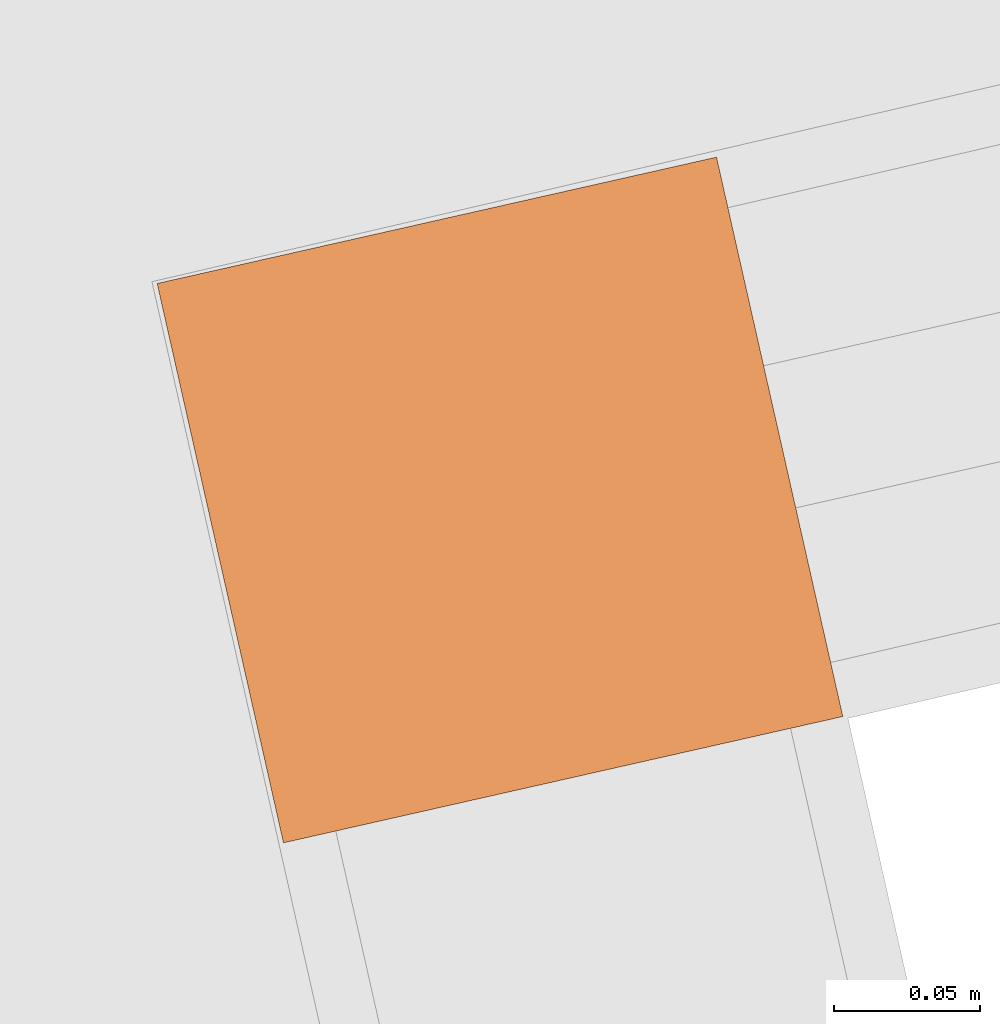
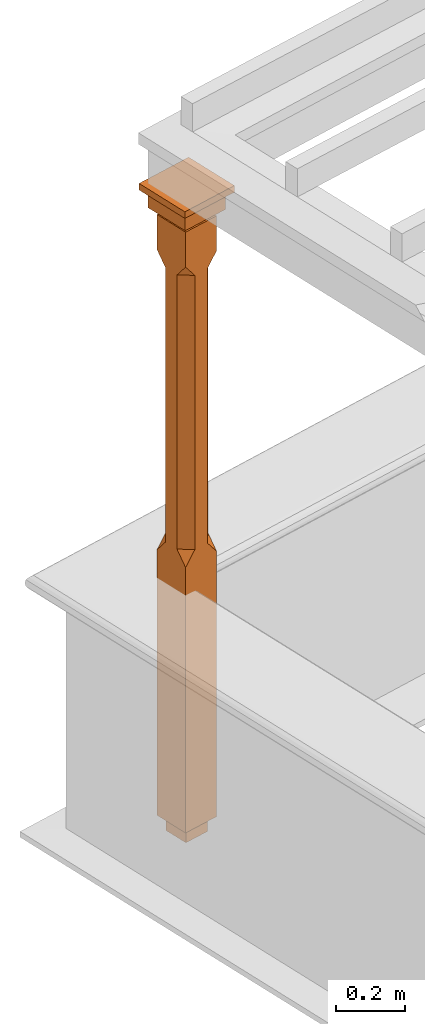
# One storey, part 11 of 11: 1 proxy.
"""IFC2X3 building model written with IfcOpenShell, lengths in metres."""

from ifc_helpers import new_model, si_unit, frame, origin, place, context, subcontext, project, spatial, faceted_brep, element, save


model = new_model("IFC2X3")

# Units and contexts
model_context = context("Model", 3, world=origin())
body_context = subcontext(model_context, "Body", "Model", "MODEL_VIEW")
ifc_project = project(units=[si_unit("PLANEANGLEUNIT", "RADIAN"), si_unit("MASSUNIT", "GRAM", prefix="KILO"), si_unit("FORCEUNIT", "NEWTON", prefix="KILO"), si_unit("LENGTHUNIT", "METRE")], contexts=[model_context])

# Site, building, storey
site_placement = place(None, origin())
site = spatial("IfcSite", under=ifc_project, at=site_placement, CompositionType="ELEMENT")
building_placement = place(None, origin())
building = spatial("IfcBuilding", under=site, at=building_placement, Name="Building plot-10", CompositionType="ELEMENT")
storey_placement = place(None, frame((0.0, 0.0, 4.6)))
storey = spatial("IfcBuildingStorey", under=building, at=storey_placement, Name="Floor 1", CompositionType="ELEMENT", Elevation=4.6)

# Proxy
proxy_placement = place(storey_placement, frame((40.7924789671052, 23.8504203509661, 0.0), z_axis=(0.0, 0.0, 1.0), x_axis=(0.220304872732348, -0.975431065247762, 0.0)))
element("IfcBuildingElementProxy", 1, at=proxy_placement, inside=storey, Name="pergola post", CompositionType="ELEMENT", context=body_context, shape_type="Brep", held_by="IfcProductRepresentation", body=[
    faceted_brep([(0.0246, -0.0615, 2.02), (0.0615, -0.0246, 2.02), (0.0615, -0.0615, 2.066667), (0.0615, -0.0246, 1.044444), (0.0246, -0.0615, 1.044444), (0.0615, 0.0246, 2.02), (0.0615, 0.0615, 2.066667), (-0.0246, -0.0615, 2.02), (-0.0615, -0.0615, 2.066667), (-0.0246, -0.0615, 1.044444), (0.0615, -0.0615, 0.997778), (0.0615, 0.0246, 1.044444), (0.0246, 0.0615, 2.02), (0.0615, 0.0615, 2.191111), (0.0615, -0.0615, 2.191111), (-0.0615, -0.0615, 2.191111), (-0.0615, -0.0246, 2.02), (-0.0615, -0.0246, 1.044444), (-0.0615, -0.0615, 0.997778), (0.0615, 0.0615, 0.997778), (0.0246, 0.0615, 1.044444), (-0.0246, 0.0615, 2.02), (-0.0615, 0.0615, 2.066667), (0.04305, 0.04305, 2.191111), (0.04305, -0.04305, 2.191111), (-0.0615, 0.0615, 2.191111), (-0.04305, -0.04305, 2.191111), (-0.0615, 0.0246, 2.02), (-0.0615, 0.0246, 1.044444), (0.0615, -0.0615, 0.053333), (-0.0615, -0.0615, 0.053333), (0.0615, 0.0615, 0.053333), (-0.0246, 0.0615, 1.044444), (-0.04305, 0.04305, 2.191111), (0.04305, 0.04305, 2.214444), (0.04305, -0.04305, 2.214444), (-0.04305, -0.04305, 2.214444), (-0.0615, 0.0615, 0.997778), (-0.0615, 0.0615, 0.053333), (-0.04305, -0.04305, 0.053333), (0.04305, -0.04305, 0.053333), (0.04305, 0.04305, 0.053333), (-0.04305, 0.04305, 2.214444), (0.07995, 0.07995, 2.214444), (0.07995, -0.07995, 2.214444), (-0.07995, -0.07995, 2.214444), (-0.04305, 0.04305, 0.053333), (-0.04305, -0.04305, 0.0), (0.04305, -0.04305, 0.0), (0.04305, 0.04305, 0.0), (-0.07995, 0.07995, 2.214444), (0.07995, 0.07995, 2.276667), (0.07995, -0.07995, 2.276667), (-0.07995, -0.07995, 2.276667), (-0.04305, 0.04305, 0.0), (-0.07995, 0.07995, 2.276667), (0.0984, 0.0984, 2.276667), (0.0984, -0.0984, 2.276667), (-0.0984, -0.0984, 2.276667), (-0.0984, 0.0984, 2.276667), (0.0984, 0.0984, 2.3), (0.0984, -0.0984, 2.3), (-0.0984, -0.0984, 2.3), (-0.0984, 0.0984, 2.3)], [[[0, 1, 2]], [[3, 1, 0, 4]], [[1, 5, 6, 2]], [[7, 0, 2, 8]], [[4, 0, 7, 9]], [[3, 4, 10]], [[1, 3, 11, 5]], [[5, 12, 6]], [[13, 14, 2, 6]], [[15, 8, 2, 14]], [[8, 16, 7]], [[9, 7, 16, 17]], [[9, 18, 10, 4]], [[3, 10, 19, 11]], [[20, 12, 5, 11]], [[21, 22, 6, 12]], [[14, 13, 23, 24]], [[13, 6, 22, 25]], [[25, 22, 8, 15]], [[26, 15, 14, 24]], [[16, 8, 22, 27]], [[27, 28, 17, 16]], [[17, 18, 9]], [[29, 10, 18, 30]], [[31, 19, 10, 29]], [[20, 11, 19]], [[12, 20, 32, 21]], [[21, 27, 22]], [[33, 23, 13, 25]], [[23, 34, 35, 24]], [[26, 33, 25, 15]], [[36, 26, 24, 35]], [[28, 27, 21, 32]], [[17, 28, 37, 18]], [[38, 30, 18, 37]], [[29, 30, 39, 40]], [[31, 38, 37, 19]], [[40, 41, 31, 29]], [[32, 20, 19, 37]], [[33, 42, 34, 23]], [[43, 44, 35, 34]], [[42, 33, 26, 36]], [[36, 35, 44, 45]], [[28, 32, 37]], [[46, 39, 30, 38]], [[39, 47, 48, 40]], [[46, 38, 31, 41]], [[49, 41, 40, 48]], [[43, 34, 42, 50]], [[43, 51, 52, 44]], [[45, 50, 42, 36]], [[53, 45, 44, 52]], [[46, 54, 47, 39]], [[54, 46, 41, 49]], [[50, 55, 51, 43]], [[56, 57, 52, 51]], [[55, 50, 45, 53]], [[53, 52, 57, 58]], [[56, 51, 55, 59]], [[56, 60, 61, 57]], [[58, 59, 55, 53]], [[62, 58, 57, 61]], [[59, 63, 60, 56]], [[63, 62, 61, 60]], [[58, 62, 63, 59]], [[47, 54, 49, 48]]]),
])

save(model, "model.ifc")
